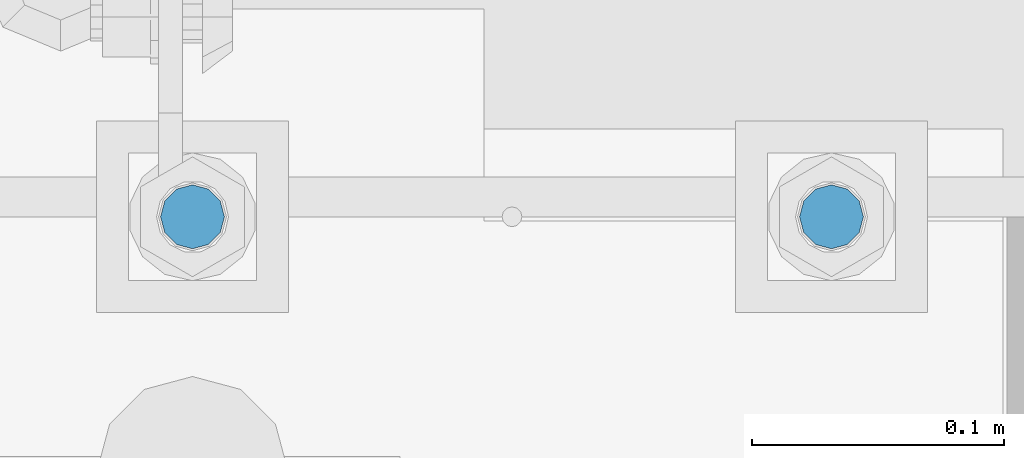
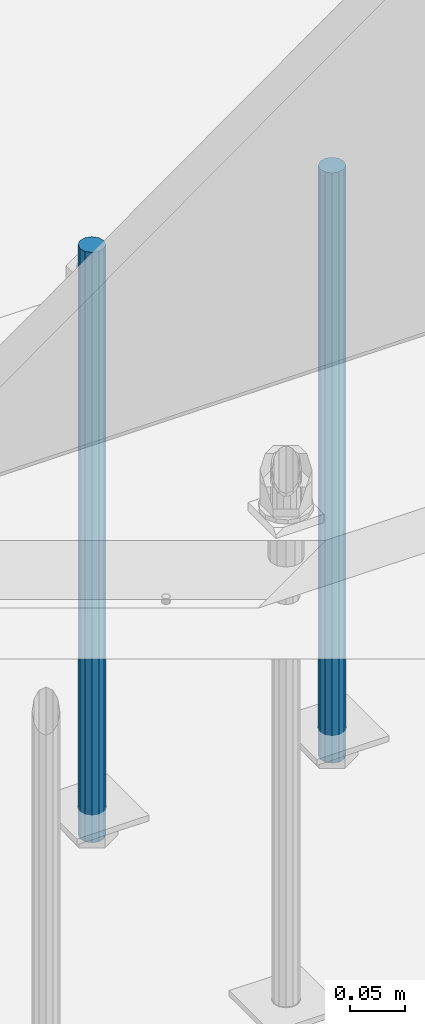
# One storey, part 960 of 1763: 2 columns, 1 element without a shape of its own.
"""IFC2X3 building model written with IfcOpenShell, lengths in millimetres."""

from ifc_helpers import new_model, si_unit, frame, origin_with_axes, place, context, subcontext, project, spatial, faceted_brep, material, type_object, element, aggregate, save


model = new_model("IFC2X3")

# Units and contexts
model_context = context("Model", 3, precision=1e-05, world=origin_with_axes())
body_context = subcontext(model_context, "Body", "Model", "MODEL_VIEW")
ifc_project = project(units=[si_unit("LENGTHUNIT", "METRE", prefix="MILLI"), si_unit("AREAUNIT", "SQUARE_METRE"), si_unit("VOLUMEUNIT", "CUBIC_METRE"), si_unit("MASSUNIT", "GRAM", prefix="KILO"), si_unit("TIMEUNIT", "SECOND"), si_unit("PLANEANGLEUNIT", "RADIAN"), si_unit("SOLIDANGLEUNIT", "STERADIAN"), si_unit("THERMODYNAMICTEMPERATUREUNIT", "DEGREE_CELSIUS"), si_unit("LUMINOUSINTENSITYUNIT", "LUMEN")], contexts=[model_context])

# Site, building, storey
site_placement = place(None, origin_with_axes())
site = spatial("IfcSite", under=ifc_project, at=site_placement, CompositionType="ELEMENT")
building_placement = place(site_placement, origin_with_axes())
building = spatial("IfcBuilding", under=site, at=building_placement, Name="Undefined", CompositionType="ELEMENT")
storey_placement = place(building_placement, origin_with_axes())
storey = spatial("IfcBuildingStorey", under=building, at=storey_placement, Name="Undefined", CompositionType="ELEMENT", Elevation=0.0)

# Assembly, columns
assembly_placement = place(storey_placement, origin_with_axes())
assembly = element("IfcElementAssembly", 1, at=assembly_placement, inside=storey, Name="TEMPLATE", AssemblyPlace="NOTDEFINED", PredefinedType="RIGID_FRAME")
ifc_material = material(Name="STEEL/F1554-55")
column_type = type_object("IfcColumnType", PredefinedType="NOTDEFINED")
column_1_placement = place(assembly_placement, frame((-34695.8372736984, 52298.6, -126.999999999997), z_axis=(-1.0, 0.0, 0.0), x_axis=(0.0, 0.0, -1.0)))
column_1 = element("IfcColumn", 2, at=column_1_placement, type_object=column_type, material=ifc_material, Name="ALL THREADED ROD", context=body_context, shape_type="Brep", body=[
    faceted_brep([(0.0, -12.6999999999971, -1.81898940354586e-12), (0.0, -10.9985226280623, -6.35000000000582), (660.399, -10.9985226280623, -6.35000000000582), (660.399, -12.6999999999971, 0.0), (0.0, -6.34999999999854, -10.9985226280696), (660.399, -6.34999999999854, -10.9985226280696), (3.63797880709171e-12, 0.0, -12.6999998092651), (660.399, 0.0, -12.6999999999971), (0.0, 6.34999999999854, -10.9985226280696), (660.399, 6.34999999999854, -10.9985226280696), (0.0, 10.9985226280623, -6.35000000000582), (660.399, 10.9985226280623, -6.35000000000582), (0.0, 12.6999999999971, -1.81898940354586e-12), (660.399, 12.6999999999971, 0.0), (0.0, 10.9985226280623, 6.35000000000582), (660.399, 10.9985226280623, 6.35000000000582), (0.0, 6.34999999999854, 10.9985226280696), (660.399, 6.34999999999854, 10.9985226280696), (-3.63797880709171e-12, 0.0, 12.6999998092651), (660.399, 0.0, 12.6999999999971), (0.0, -6.34999999999854, 10.9985226280696), (660.399, -6.34999999999854, 10.9985226280696), (0.0, -10.9985226280623, 6.35000000000582), (660.399, -10.9985226280623, 6.35000000000582)], [[[0, 1, 2, 3]], [[1, 4, 5, 2]], [[4, 6, 7, 5]], [[6, 8, 9, 7]], [[8, 10, 11, 9]], [[10, 12, 13, 11]], [[12, 14, 15, 13]], [[14, 16, 17, 15]], [[16, 18, 19, 17]], [[18, 20, 21, 19]], [[20, 22, 23, 21]], [[22, 0, 3, 23]], [[5, 7, 9, 11, 13, 15, 17, 19, 21, 23, 3, 2]], [[22, 20, 18, 16, 14, 12, 10, 8, 6, 4, 1, 0]]]),
])
column_2_placement = place(assembly_placement, frame((-34949.8372736984, 52298.6, -126.999999999997), z_axis=(-1.0, 0.0, 0.0), x_axis=(0.0, 0.0, -1.0)))
column_2 = element("IfcColumn", 3, at=column_2_placement, type_object=column_type, material=ifc_material, Name="ALL THREADED ROD", context=body_context, shape_type="Brep", body=[
    faceted_brep([(0.0, -12.6999999999971, -1.81898940354586e-12), (0.0, -10.9985226280623, -6.35000000000582), (660.399, -10.9985226280623, -6.35000000000582), (660.399, -12.6999999999971, 0.0), (0.0, -6.34999999999854, -10.9985226280696), (660.399, -6.34999999999854, -10.9985226280696), (3.63797880709171e-12, 0.0, -12.6999998092651), (660.399, 0.0, -12.6999999999971), (0.0, 6.34999999999854, -10.9985226280696), (660.399, 6.34999999999854, -10.9985226280696), (0.0, 10.9985226280623, -6.35000000000582), (660.399, 10.9985226280623, -6.35000000000582), (0.0, 12.6999999999971, -1.81898940354586e-12), (660.399, 12.6999999999971, 0.0), (0.0, 10.9985226280623, 6.35000000000582), (660.399, 10.9985226280623, 6.35000000000582), (0.0, 6.34999999999854, 10.9985226280696), (660.399, 6.34999999999854, 10.9985226280696), (-3.63797880709171e-12, 0.0, 12.6999998092651), (660.399, 0.0, 12.6999999999971), (0.0, -6.34999999999854, 10.9985226280696), (660.399, -6.34999999999854, 10.9985226280696), (0.0, -10.9985226280623, 6.35000000000582), (660.399, -10.9985226280623, 6.35000000000582)], [[[0, 1, 2, 3]], [[1, 4, 5, 2]], [[4, 6, 7, 5]], [[6, 8, 9, 7]], [[8, 10, 11, 9]], [[10, 12, 13, 11]], [[12, 14, 15, 13]], [[14, 16, 17, 15]], [[16, 18, 19, 17]], [[18, 20, 21, 19]], [[20, 22, 23, 21]], [[22, 0, 3, 23]], [[5, 7, 9, 11, 13, 15, 17, 19, 21, 23, 3, 2]], [[22, 20, 18, 16, 14, 12, 10, 8, 6, 4, 1, 0]]]),
])
aggregate(assembly, [column_1, column_2])

save(model, "model.ifc")
